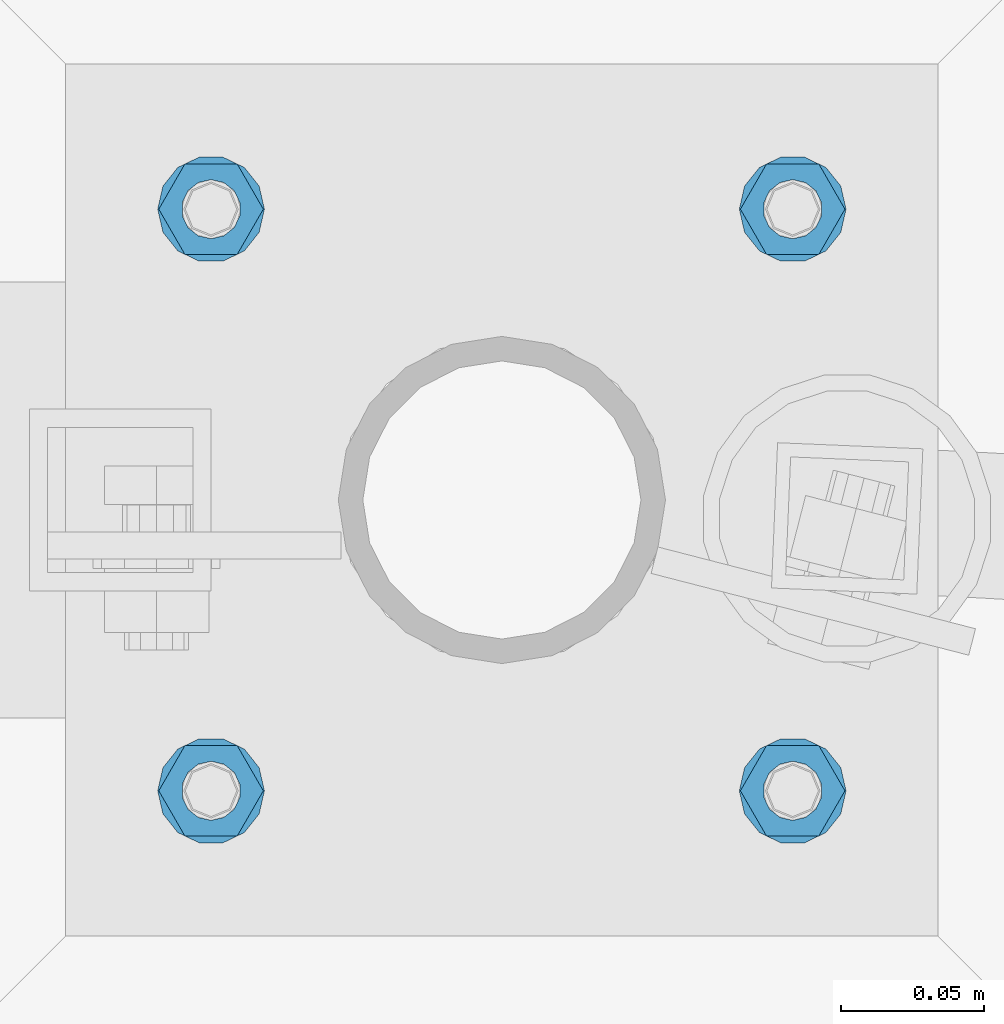
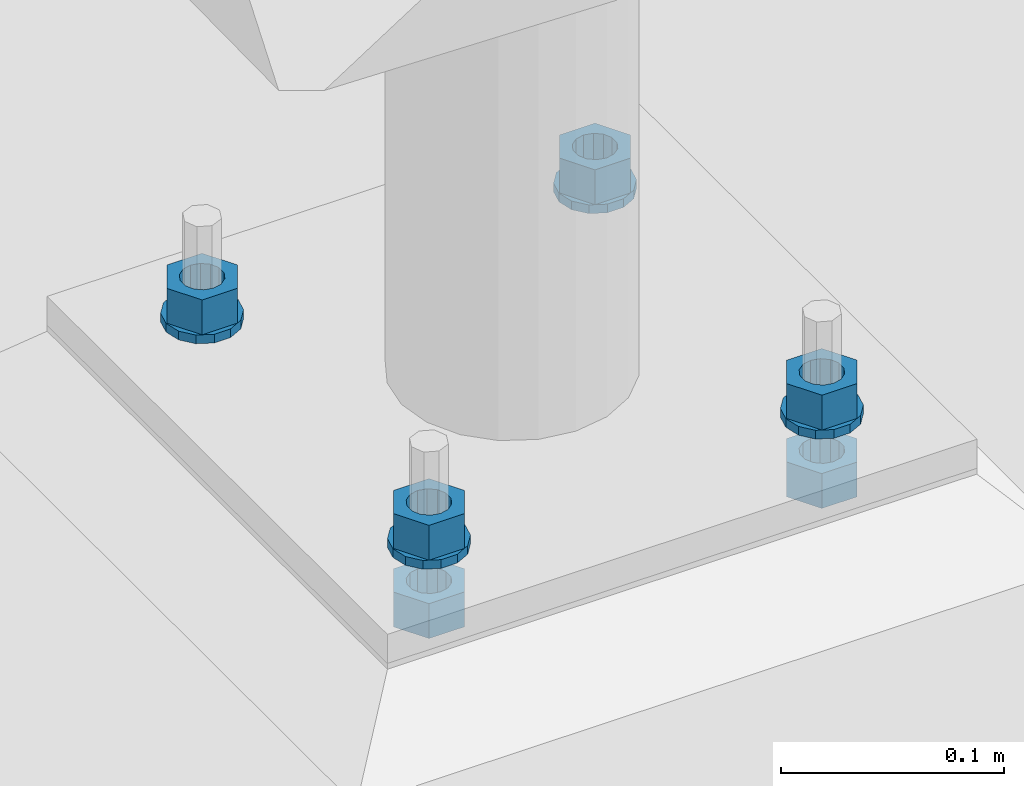
# One storey, part 631 of 975: 10 beams.
"""IFC2X3 building model written with IfcOpenShell, lengths in millimetres."""

from ifc_helpers import new_model, si_unit, frame, origin_with_axes, place, context, subcontext, project, spatial, faceted_brep, material, type_object, element, save


model = new_model("IFC2X3")

# Units and contexts
model_context = context("Model", 3, precision=1e-05, world=origin_with_axes())
body_context = subcontext(model_context, "Body", "Model", "MODEL_VIEW")
ifc_project = project(units=[si_unit("LENGTHUNIT", "METRE", prefix="MILLI"), si_unit("AREAUNIT", "SQUARE_METRE"), si_unit("VOLUMEUNIT", "CUBIC_METRE"), si_unit("MASSUNIT", "GRAM", prefix="KILO"), si_unit("TIMEUNIT", "SECOND"), si_unit("PLANEANGLEUNIT", "RADIAN"), si_unit("SOLIDANGLEUNIT", "STERADIAN"), si_unit("THERMODYNAMICTEMPERATUREUNIT", "DEGREE_CELSIUS"), si_unit("LUMINOUSINTENSITYUNIT", "LUMEN")], contexts=[model_context])

# Site, building, storey
site_placement = place(None, origin_with_axes())
site = spatial("IfcSite", under=ifc_project, at=site_placement, CompositionType="ELEMENT")
building_placement = place(site_placement, origin_with_axes())
building = spatial("IfcBuilding", under=site, at=building_placement, Name="Undefined", CompositionType="ELEMENT")
storey_placement = place(building_placement, origin_with_axes())
storey = spatial("IfcBuildingStorey", under=building, at=storey_placement, Name="Undefined", CompositionType="ELEMENT", Elevation=0.0)

# Beams
ifc_material = material(Name="STEEL/A36")
beam_type_1 = type_object("IfcBeamType", Name="3/4_WASHER", PredefinedType="NOTDEFINED")
beam_1_placement = place(storey_placement, frame((16322.6750015259, 29860.875, -242.887499999999), z_axis=(0.0, -1.0, 0.0), x_axis=(0.0, 0.0, -1.0)))
element("IfcBeam", 1, at=beam_1_placement, inside=storey, type_object=beam_type_1, material=ifc_material, Name="WASHER", ObjectType="3/4_WASHER", context=body_context, shape_type="Brep", body=[
    faceted_brep([(0.0, -18.6499996185303, 0.0), (0.0, -16.8030690426876, -8.09193156902904), (4.76250000000073, -16.8030690426876, -8.09193156902904), (4.76250000000073, -18.6499996185303, 0.0), (0.0, -11.6280845668225, -14.5811568497838), (4.76250000000073, -11.6280845668225, -14.5811568497838), (0.0, -4.15001533340001, -18.1824051902857), (4.76250000000073, -4.15001533340001, -18.1824051902857), (0.0, 4.15001533340001, -18.1824051902857), (4.76250000000073, 4.15001533340001, -18.1824051902857), (0.0, 11.6280845668234, -14.5811568497838), (4.76250000000073, 11.6280845668234, -14.5811568497838), (0.0, 16.8030690426876, -8.09193156902904), (4.76250000000073, 16.8030690426876, -8.09193156902904), (0.0, 18.6499996185303, 0.0), (4.76250000000073, 18.6499996185303, 0.0), (0.0, 16.8030690426876, 8.09193156902904), (4.76250000000073, 16.8030690426876, 8.09193156902904), (0.0, 11.6280845668225, 14.5811568497838), (4.76250000000073, 11.6280845668225, 14.5811568497838), (0.0, 4.15001533340001, 18.1824051902857), (4.76250000000073, 4.15001533340001, 18.1824051902857), (0.0, -4.15001533340001, 18.1824051902857), (4.76250000000073, -4.15001533340001, 18.1824051902857), (0.0, -11.6280845668234, 14.5811568497838), (4.76250000000073, -11.6280845668234, 14.5811568497838), (0.0, -16.8030690426876, 8.09193156902904), (4.76250000000073, -16.8030690426876, 8.09193156902904), (0.0, 0.0, 10.3199996948242), (0.0, 4.47768005528269, 9.29799844179911), (4.76250000000073, 4.47768005528269, 9.29799844179911), (4.76250000000073, 0.0, 10.3199996948242), (0.0, 8.06850066047446, 6.43441456490817), (4.76250000000073, 8.06850066047446, 6.43441456490817), (0.0, 10.0612557561917, 2.29641597052117), (4.76250000000073, 10.0612557561917, 2.29641597052117), (0.0, 10.0612557561917, -2.29641597052117), (4.76250000000073, 10.0612557561917, -2.29641597052117), (0.0, 8.06850066047446, -6.43441456490814), (4.76250000000073, 8.06850066047446, -6.43441456490814), (0.0, 4.47768005528269, -9.29799844179908), (4.76250000000073, 4.47768005528269, -9.29799844179908), (0.0, 0.0, -10.3199996948242), (4.76250000000073, 0.0, -10.3199996948242), (0.0, -4.47768005528269, -9.29799844179911), (4.76250000000073, -4.47768005528269, -9.29799844179911), (0.0, -8.06850066047446, -6.43441456490817), (4.76250000000073, -8.06850066047446, -6.43441456490817), (0.0, -10.0612557561917, -2.29641597052117), (4.76250000000073, -10.0612557561917, -2.29641597052117), (0.0, -10.0612557561917, 2.29641597052117), (4.76250000000073, -10.0612557561917, 2.29641597052117), (0.0, -8.06850066047446, 6.43441456490814), (4.76250000000073, -8.06850066047446, 6.43441456490814), (0.0, -4.47768005528269, 9.29799844179908), (4.76250000000073, -4.47768005528269, 9.29799844179908)], [[[0, 1, 2, 3]], [[1, 4, 5, 2]], [[4, 6, 7, 5]], [[6, 8, 9, 7]], [[8, 10, 11, 9]], [[10, 12, 13, 11]], [[12, 14, 15, 13]], [[14, 16, 17, 15]], [[16, 18, 19, 17]], [[18, 20, 21, 19]], [[20, 22, 23, 21]], [[22, 24, 25, 23]], [[24, 26, 27, 25]], [[26, 0, 3, 27]], [[28, 29, 30, 31]], [[29, 32, 33, 30]], [[32, 34, 35, 33]], [[34, 36, 37, 35]], [[36, 38, 39, 37]], [[38, 40, 41, 39]], [[40, 42, 43, 41]], [[42, 44, 45, 43]], [[44, 46, 47, 45]], [[46, 48, 49, 47]], [[48, 50, 51, 49]], [[50, 52, 53, 51]], [[52, 54, 55, 53]], [[54, 28, 31, 55]], [[5, 7, 9, 11, 13, 15, 17, 19, 21, 23, 25, 27, 3, 2], [33, 35, 37, 39, 41, 43, 45, 47, 49, 51, 53, 55, 31, 30]], [[26, 24, 22, 20, 18, 16, 14, 12, 10, 8, 6, 4, 1, 0], [54, 52, 50, 48, 46, 44, 42, 40, 38, 36, 34, 32, 29, 28]]]),
])
beam_2_placement = place(storey_placement, frame((16525.8749984741, 29860.875, -242.887499999999), z_axis=(0.0, 1.0, 0.0), x_axis=(0.0, 0.0, -1.0)))
element("IfcBeam", 2, at=beam_2_placement, inside=storey, type_object=beam_type_1, material=ifc_material, Name="WASHER", ObjectType="3/4_WASHER", context=body_context, shape_type="Brep", body=[
    faceted_brep([(0.0, -18.6499996185303, 0.0), (0.0, -16.8030690426876, -8.09193156902904), (4.76250000000073, -16.8030690426876, -8.09193156902904), (4.76250000000073, -18.6499996185303, 0.0), (0.0, -11.6280845668225, -14.5811568497838), (4.76250000000073, -11.6280845668225, -14.5811568497838), (0.0, -4.15001533340001, -18.1824051902857), (4.76250000000073, -4.15001533340001, -18.1824051902857), (0.0, 4.15001533340001, -18.1824051902857), (4.76250000000073, 4.15001533340001, -18.1824051902857), (0.0, 11.6280845668234, -14.5811568497838), (4.76250000000073, 11.6280845668234, -14.5811568497838), (0.0, 16.8030690426876, -8.09193156902904), (4.76250000000073, 16.8030690426876, -8.09193156902904), (0.0, 18.6499996185303, 0.0), (4.76250000000073, 18.6499996185303, 0.0), (0.0, 16.8030690426876, 8.09193156902904), (4.76250000000073, 16.8030690426876, 8.09193156902904), (0.0, 11.6280845668225, 14.5811568497838), (4.76250000000073, 11.6280845668225, 14.5811568497838), (0.0, 4.15001533340001, 18.1824051902857), (4.76250000000073, 4.15001533340001, 18.1824051902857), (0.0, -4.15001533340001, 18.1824051902857), (4.76250000000073, -4.15001533340001, 18.1824051902857), (0.0, -11.6280845668234, 14.5811568497838), (4.76250000000073, -11.6280845668234, 14.5811568497838), (0.0, -16.8030690426876, 8.09193156902904), (4.76250000000073, -16.8030690426876, 8.09193156902904), (0.0, 0.0, 10.3199996948242), (0.0, 4.47768005528269, 9.29799844179911), (4.76250000000073, 4.47768005528269, 9.29799844179911), (4.76250000000073, 0.0, 10.3199996948242), (0.0, 8.06850066047446, 6.43441456490817), (4.76250000000073, 8.06850066047446, 6.43441456490817), (0.0, 10.0612557561917, 2.29641597052117), (4.76250000000073, 10.0612557561917, 2.29641597052117), (0.0, 10.0612557561917, -2.29641597052117), (4.76250000000073, 10.0612557561917, -2.29641597052117), (0.0, 8.06850066047446, -6.43441456490814), (4.76250000000073, 8.06850066047446, -6.43441456490814), (0.0, 4.47768005528269, -9.29799844179908), (4.76250000000073, 4.47768005528269, -9.29799844179908), (0.0, 0.0, -10.3199996948242), (4.76250000000073, 0.0, -10.3199996948242), (0.0, -4.47768005528269, -9.29799844179911), (4.76250000000073, -4.47768005528269, -9.29799844179911), (0.0, -8.06850066047446, -6.43441456490817), (4.76250000000073, -8.06850066047446, -6.43441456490817), (0.0, -10.0612557561917, -2.29641597052117), (4.76250000000073, -10.0612557561917, -2.29641597052117), (0.0, -10.0612557561917, 2.29641597052117), (4.76250000000073, -10.0612557561917, 2.29641597052117), (0.0, -8.06850066047446, 6.43441456490814), (4.76250000000073, -8.06850066047446, 6.43441456490814), (0.0, -4.47768005528269, 9.29799844179908), (4.76250000000073, -4.47768005528269, 9.29799844179908)], [[[0, 1, 2, 3]], [[1, 4, 5, 2]], [[4, 6, 7, 5]], [[6, 8, 9, 7]], [[8, 10, 11, 9]], [[10, 12, 13, 11]], [[12, 14, 15, 13]], [[14, 16, 17, 15]], [[16, 18, 19, 17]], [[18, 20, 21, 19]], [[20, 22, 23, 21]], [[22, 24, 25, 23]], [[24, 26, 27, 25]], [[26, 0, 3, 27]], [[28, 29, 30, 31]], [[29, 32, 33, 30]], [[32, 34, 35, 33]], [[34, 36, 37, 35]], [[36, 38, 39, 37]], [[38, 40, 41, 39]], [[40, 42, 43, 41]], [[42, 44, 45, 43]], [[44, 46, 47, 45]], [[46, 48, 49, 47]], [[48, 50, 51, 49]], [[50, 52, 53, 51]], [[52, 54, 55, 53]], [[54, 28, 31, 55]], [[5, 7, 9, 11, 13, 15, 17, 19, 21, 23, 25, 27, 3, 2], [33, 35, 37, 39, 41, 43, 45, 47, 49, 51, 53, 55, 31, 30]], [[26, 24, 22, 20, 18, 16, 14, 12, 10, 8, 6, 4, 1, 0], [54, 52, 50, 48, 46, 44, 42, 40, 38, 36, 34, 32, 29, 28]]]),
])
beam_3_placement = place(storey_placement, frame((16322.6750015259, 30064.0749969482, -242.887499999999), z_axis=(0.0, -1.0, 0.0), x_axis=(0.0, 0.0, -1.0)))
element("IfcBeam", 3, at=beam_3_placement, inside=storey, type_object=beam_type_1, material=ifc_material, Name="WASHER", ObjectType="3/4_WASHER", context=body_context, shape_type="Brep", body=[
    faceted_brep([(0.0, -18.6499996185303, 0.0), (0.0, -16.8030690426876, -8.09193156902904), (4.76250000000073, -16.8030690426876, -8.09193156902904), (4.76250000000073, -18.6499996185303, 0.0), (0.0, -11.6280845668225, -14.5811568497838), (4.76250000000073, -11.6280845668225, -14.5811568497838), (0.0, -4.15001533340001, -18.1824051902857), (4.76250000000073, -4.15001533340001, -18.1824051902857), (0.0, 4.15001533340001, -18.1824051902857), (4.76250000000073, 4.15001533340001, -18.1824051902857), (0.0, 11.6280845668234, -14.5811568497838), (4.76250000000073, 11.6280845668234, -14.5811568497838), (0.0, 16.8030690426876, -8.09193156902904), (4.76250000000073, 16.8030690426876, -8.09193156902904), (0.0, 18.6499996185303, 0.0), (4.76250000000073, 18.6499996185303, 0.0), (0.0, 16.8030690426876, 8.09193156902904), (4.76250000000073, 16.8030690426876, 8.09193156902904), (0.0, 11.6280845668225, 14.5811568497838), (4.76250000000073, 11.6280845668225, 14.5811568497838), (0.0, 4.15001533340001, 18.1824051902857), (4.76250000000073, 4.15001533340001, 18.1824051902857), (0.0, -4.15001533340001, 18.1824051902857), (4.76250000000073, -4.15001533340001, 18.1824051902857), (0.0, -11.6280845668234, 14.5811568497838), (4.76250000000073, -11.6280845668234, 14.5811568497838), (0.0, -16.8030690426876, 8.09193156902904), (4.76250000000073, -16.8030690426876, 8.09193156902904), (0.0, 0.0, 10.3199996948242), (0.0, 4.47768005528269, 9.29799844179911), (4.76250000000073, 4.47768005528269, 9.29799844179911), (4.76250000000073, 0.0, 10.3199996948242), (0.0, 8.06850066047446, 6.43441456490817), (4.76250000000073, 8.06850066047446, 6.43441456490817), (0.0, 10.0612557561917, 2.29641597052117), (4.76250000000073, 10.0612557561917, 2.29641597052117), (0.0, 10.0612557561917, -2.29641597052117), (4.76250000000073, 10.0612557561917, -2.29641597052117), (0.0, 8.06850066047446, -6.43441456490814), (4.76250000000073, 8.06850066047446, -6.43441456490814), (0.0, 4.47768005528269, -9.29799844179908), (4.76250000000073, 4.47768005528269, -9.29799844179908), (0.0, 0.0, -10.3199996948242), (4.76250000000073, 0.0, -10.3199996948242), (0.0, -4.47768005528269, -9.29799844179911), (4.76250000000073, -4.47768005528269, -9.29799844179911), (0.0, -8.06850066047446, -6.43441456490817), (4.76250000000073, -8.06850066047446, -6.43441456490817), (0.0, -10.0612557561917, -2.29641597052117), (4.76250000000073, -10.0612557561917, -2.29641597052117), (0.0, -10.0612557561917, 2.29641597052117), (4.76250000000073, -10.0612557561917, 2.29641597052117), (0.0, -8.06850066047446, 6.43441456490814), (4.76250000000073, -8.06850066047446, 6.43441456490814), (0.0, -4.47768005528269, 9.29799844179908), (4.76250000000073, -4.47768005528269, 9.29799844179908)], [[[0, 1, 2, 3]], [[1, 4, 5, 2]], [[4, 6, 7, 5]], [[6, 8, 9, 7]], [[8, 10, 11, 9]], [[10, 12, 13, 11]], [[12, 14, 15, 13]], [[14, 16, 17, 15]], [[16, 18, 19, 17]], [[18, 20, 21, 19]], [[20, 22, 23, 21]], [[22, 24, 25, 23]], [[24, 26, 27, 25]], [[26, 0, 3, 27]], [[28, 29, 30, 31]], [[29, 32, 33, 30]], [[32, 34, 35, 33]], [[34, 36, 37, 35]], [[36, 38, 39, 37]], [[38, 40, 41, 39]], [[40, 42, 43, 41]], [[42, 44, 45, 43]], [[44, 46, 47, 45]], [[46, 48, 49, 47]], [[48, 50, 51, 49]], [[50, 52, 53, 51]], [[52, 54, 55, 53]], [[54, 28, 31, 55]], [[5, 7, 9, 11, 13, 15, 17, 19, 21, 23, 25, 27, 3, 2], [33, 35, 37, 39, 41, 43, 45, 47, 49, 51, 53, 55, 31, 30]], [[26, 24, 22, 20, 18, 16, 14, 12, 10, 8, 6, 4, 1, 0], [54, 52, 50, 48, 46, 44, 42, 40, 38, 36, 34, 32, 29, 28]]]),
])
beam_4_placement = place(storey_placement, frame((16525.8749984741, 30064.0749969482, -242.887499999999), z_axis=(0.0, 1.0, 0.0), x_axis=(0.0, 0.0, -1.0)))
element("IfcBeam", 4, at=beam_4_placement, inside=storey, type_object=beam_type_1, material=ifc_material, Name="WASHER", ObjectType="3/4_WASHER", context=body_context, shape_type="Brep", body=[
    faceted_brep([(0.0, -18.6499996185303, 0.0), (0.0, -16.8030690426876, -8.09193156902904), (4.76250000000073, -16.8030690426876, -8.09193156902904), (4.76250000000073, -18.6499996185303, 0.0), (0.0, -11.6280845668225, -14.5811568497838), (4.76250000000073, -11.6280845668225, -14.5811568497838), (0.0, -4.15001533340001, -18.1824051902857), (4.76250000000073, -4.15001533340001, -18.1824051902857), (0.0, 4.15001533340001, -18.1824051902857), (4.76250000000073, 4.15001533340001, -18.1824051902857), (0.0, 11.6280845668234, -14.5811568497838), (4.76250000000073, 11.6280845668234, -14.5811568497838), (0.0, 16.8030690426876, -8.09193156902904), (4.76250000000073, 16.8030690426876, -8.09193156902904), (0.0, 18.6499996185303, 0.0), (4.76250000000073, 18.6499996185303, 0.0), (0.0, 16.8030690426876, 8.09193156902904), (4.76250000000073, 16.8030690426876, 8.09193156902904), (0.0, 11.6280845668225, 14.5811568497838), (4.76250000000073, 11.6280845668225, 14.5811568497838), (0.0, 4.15001533340001, 18.1824051902857), (4.76250000000073, 4.15001533340001, 18.1824051902857), (0.0, -4.15001533340001, 18.1824051902857), (4.76250000000073, -4.15001533340001, 18.1824051902857), (0.0, -11.6280845668234, 14.5811568497838), (4.76250000000073, -11.6280845668234, 14.5811568497838), (0.0, -16.8030690426876, 8.09193156902904), (4.76250000000073, -16.8030690426876, 8.09193156902904), (0.0, 0.0, 10.3199996948242), (0.0, 4.47768005528269, 9.29799844179911), (4.76250000000073, 4.47768005528269, 9.29799844179911), (4.76250000000073, 0.0, 10.3199996948242), (0.0, 8.06850066047446, 6.43441456490817), (4.76250000000073, 8.06850066047446, 6.43441456490817), (0.0, 10.0612557561917, 2.29641597052117), (4.76250000000073, 10.0612557561917, 2.29641597052117), (0.0, 10.0612557561917, -2.29641597052117), (4.76250000000073, 10.0612557561917, -2.29641597052117), (0.0, 8.06850066047446, -6.43441456490814), (4.76250000000073, 8.06850066047446, -6.43441456490814), (0.0, 4.47768005528269, -9.29799844179908), (4.76250000000073, 4.47768005528269, -9.29799844179908), (0.0, 0.0, -10.3199996948242), (4.76250000000073, 0.0, -10.3199996948242), (0.0, -4.47768005528269, -9.29799844179911), (4.76250000000073, -4.47768005528269, -9.29799844179911), (0.0, -8.06850066047446, -6.43441456490817), (4.76250000000073, -8.06850066047446, -6.43441456490817), (0.0, -10.0612557561917, -2.29641597052117), (4.76250000000073, -10.0612557561917, -2.29641597052117), (0.0, -10.0612557561917, 2.29641597052117), (4.76250000000073, -10.0612557561917, 2.29641597052117), (0.0, -8.06850066047446, 6.43441456490814), (4.76250000000073, -8.06850066047446, 6.43441456490814), (0.0, -4.47768005528269, 9.29799844179908), (4.76250000000073, -4.47768005528269, 9.29799844179908)], [[[0, 1, 2, 3]], [[1, 4, 5, 2]], [[4, 6, 7, 5]], [[6, 8, 9, 7]], [[8, 10, 11, 9]], [[10, 12, 13, 11]], [[12, 14, 15, 13]], [[14, 16, 17, 15]], [[16, 18, 19, 17]], [[18, 20, 21, 19]], [[20, 22, 23, 21]], [[22, 24, 25, 23]], [[24, 26, 27, 25]], [[26, 0, 3, 27]], [[28, 29, 30, 31]], [[29, 32, 33, 30]], [[32, 34, 35, 33]], [[34, 36, 37, 35]], [[36, 38, 39, 37]], [[38, 40, 41, 39]], [[40, 42, 43, 41]], [[42, 44, 45, 43]], [[44, 46, 47, 45]], [[46, 48, 49, 47]], [[48, 50, 51, 49]], [[50, 52, 53, 51]], [[52, 54, 55, 53]], [[54, 28, 31, 55]], [[5, 7, 9, 11, 13, 15, 17, 19, 21, 23, 25, 27, 3, 2], [33, 35, 37, 39, 41, 43, 45, 47, 49, 51, 53, 55, 31, 30]], [[26, 24, 22, 20, 18, 16, 14, 12, 10, 8, 6, 4, 1, 0], [54, 52, 50, 48, 46, 44, 42, 40, 38, 36, 34, 32, 29, 28]]]),
])
beam_type_2 = type_object("IfcBeamType", Name="3/4_HEAVY_HEX_NUT", PredefinedType="NOTDEFINED")
beam_5_placement = place(storey_placement, frame((16322.6750015259, 29860.875, -223.8375), z_axis=(0.0, -1.0, 0.0), x_axis=(0.0, 0.0, -1.0)))
element("IfcBeam", 5, at=beam_5_placement, inside=storey, type_object=beam_type_2, material=ifc_material, Name="NUT", ObjectType="3/4_HEAVY_HEX_NUT", context=body_context, shape_type="Brep", body=[
    faceted_brep([(0.0, -18.2600002288818, 0.0), (0.0, -9.13000011444092, -15.8100004196167), (19.0499999999993, -9.13000011444092, -15.8100004196167), (19.0499999999993, -18.2600002288818, 0.0), (0.0, 9.13000011444092, -15.8100004196167), (19.0499999999993, 9.13000011444092, -15.8100004196167), (0.0, 18.2600002288818, 0.0), (19.0499999999993, 18.2600002288818, 0.0), (0.0, 9.13000011444092, 15.8100004196167), (19.0499999999993, 9.13000011444092, 15.8100004196167), (0.0, -9.13000011444092, 15.8100004196167), (19.0499999999993, -9.13000011444092, 15.8100004196167), (0.0, 0.0, 10.3199996948242), (0.0, 4.47768005528269, 9.29799844179911), (19.0499999999993, 4.47768005528269, 9.29799844179911), (19.0499999999993, 0.0, 10.3199996948242), (0.0, 8.06850066047446, 6.43441456490817), (19.0499999999993, 8.06850066047446, 6.43441456490817), (0.0, 10.0612557561917, 2.29641597052117), (19.0499999999993, 10.0612557561917, 2.29641597052117), (0.0, 10.0612557561917, -2.29641597052117), (19.0499999999993, 10.0612557561917, -2.29641597052117), (0.0, 8.06850066047446, -6.43441456490814), (19.0499999999993, 8.06850066047446, -6.43441456490814), (0.0, 4.47768005528269, -9.29799844179908), (19.0499999999993, 4.47768005528269, -9.29799844179908), (0.0, 0.0, -10.3199996948242), (19.0499999999993, 0.0, -10.3199996948242), (0.0, -4.47768005528269, -9.29799844179911), (19.0499999999993, -4.47768005528269, -9.29799844179911), (0.0, -8.06850066047446, -6.43441456490817), (19.0499999999993, -8.06850066047446, -6.43441456490817), (0.0, -10.0612557561917, -2.29641597052117), (19.0499999999993, -10.0612557561917, -2.29641597052117), (0.0, -10.0612557561917, 2.29641597052117), (19.0499999999993, -10.0612557561917, 2.29641597052117), (0.0, -8.06850066047446, 6.43441456490814), (19.0499999999993, -8.06850066047446, 6.43441456490814), (0.0, -4.47768005528269, 9.29799844179908), (19.0499999999993, -4.47768005528269, 9.29799844179908)], [[[0, 1, 2, 3]], [[1, 4, 5, 2]], [[4, 6, 7, 5]], [[6, 8, 9, 7]], [[8, 10, 11, 9]], [[10, 0, 3, 11]], [[12, 13, 14, 15]], [[13, 16, 17, 14]], [[16, 18, 19, 17]], [[18, 20, 21, 19]], [[20, 22, 23, 21]], [[22, 24, 25, 23]], [[24, 26, 27, 25]], [[26, 28, 29, 27]], [[28, 30, 31, 29]], [[30, 32, 33, 31]], [[32, 34, 35, 33]], [[34, 36, 37, 35]], [[36, 38, 39, 37]], [[38, 12, 15, 39]], [[5, 7, 9, 11, 3, 2], [17, 19, 21, 23, 25, 27, 29, 31, 33, 35, 37, 39, 15, 14]], [[10, 8, 6, 4, 1, 0], [38, 36, 34, 32, 30, 28, 26, 24, 22, 20, 18, 16, 13, 12]]]),
])
beam_6_placement = place(storey_placement, frame((16525.8749984741, 29860.875, -223.8375), z_axis=(0.0, 1.0, 0.0), x_axis=(0.0, 0.0, -1.0)))
element("IfcBeam", 6, at=beam_6_placement, inside=storey, type_object=beam_type_2, material=ifc_material, Name="NUT", ObjectType="3/4_HEAVY_HEX_NUT", context=body_context, shape_type="Brep", body=[
    faceted_brep([(0.0, -18.2600002288818, 0.0), (0.0, -9.13000011444092, -15.8100004196167), (19.0499999999993, -9.13000011444092, -15.8100004196167), (19.0499999999993, -18.2600002288818, 0.0), (0.0, 9.13000011444092, -15.8100004196167), (19.0499999999993, 9.13000011444092, -15.8100004196167), (0.0, 18.2600002288818, 0.0), (19.0499999999993, 18.2600002288818, 0.0), (0.0, 9.13000011444092, 15.8100004196167), (19.0499999999993, 9.13000011444092, 15.8100004196167), (0.0, -9.13000011444092, 15.8100004196167), (19.0499999999993, -9.13000011444092, 15.8100004196167), (0.0, 0.0, 10.3199996948242), (0.0, 4.47768005528269, 9.29799844179911), (19.0499999999993, 4.47768005528269, 9.29799844179911), (19.0499999999993, 0.0, 10.3199996948242), (0.0, 8.06850066047446, 6.43441456490817), (19.0499999999993, 8.06850066047446, 6.43441456490817), (0.0, 10.0612557561917, 2.29641597052117), (19.0499999999993, 10.0612557561917, 2.29641597052117), (0.0, 10.0612557561917, -2.29641597052117), (19.0499999999993, 10.0612557561917, -2.29641597052117), (0.0, 8.06850066047446, -6.43441456490814), (19.0499999999993, 8.06850066047446, -6.43441456490814), (0.0, 4.47768005528269, -9.29799844179908), (19.0499999999993, 4.47768005528269, -9.29799844179908), (0.0, 0.0, -10.3199996948242), (19.0499999999993, 0.0, -10.3199996948242), (0.0, -4.47768005528269, -9.29799844179911), (19.0499999999993, -4.47768005528269, -9.29799844179911), (0.0, -8.06850066047446, -6.43441456490817), (19.0499999999993, -8.06850066047446, -6.43441456490817), (0.0, -10.0612557561917, -2.29641597052117), (19.0499999999993, -10.0612557561917, -2.29641597052117), (0.0, -10.0612557561917, 2.29641597052117), (19.0499999999993, -10.0612557561917, 2.29641597052117), (0.0, -8.06850066047446, 6.43441456490814), (19.0499999999993, -8.06850066047446, 6.43441456490814), (0.0, -4.47768005528269, 9.29799844179908), (19.0499999999993, -4.47768005528269, 9.29799844179908)], [[[0, 1, 2, 3]], [[1, 4, 5, 2]], [[4, 6, 7, 5]], [[6, 8, 9, 7]], [[8, 10, 11, 9]], [[10, 0, 3, 11]], [[12, 13, 14, 15]], [[13, 16, 17, 14]], [[16, 18, 19, 17]], [[18, 20, 21, 19]], [[20, 22, 23, 21]], [[22, 24, 25, 23]], [[24, 26, 27, 25]], [[26, 28, 29, 27]], [[28, 30, 31, 29]], [[30, 32, 33, 31]], [[32, 34, 35, 33]], [[34, 36, 37, 35]], [[36, 38, 39, 37]], [[38, 12, 15, 39]], [[5, 7, 9, 11, 3, 2], [17, 19, 21, 23, 25, 27, 29, 31, 33, 35, 37, 39, 15, 14]], [[10, 8, 6, 4, 1, 0], [38, 36, 34, 32, 30, 28, 26, 24, 22, 20, 18, 16, 13, 12]]]),
])
beam_7_placement = place(storey_placement, frame((16322.6750015259, 30064.0749969482, -223.8375), z_axis=(0.0, -1.0, 0.0), x_axis=(0.0, 0.0, -1.0)))
element("IfcBeam", 7, at=beam_7_placement, inside=storey, type_object=beam_type_2, material=ifc_material, Name="NUT", ObjectType="3/4_HEAVY_HEX_NUT", context=body_context, shape_type="Brep", body=[
    faceted_brep([(0.0, -18.2600002288818, 0.0), (0.0, -9.13000011444092, -15.8100004196167), (19.0499999999993, -9.13000011444092, -15.8100004196167), (19.0499999999993, -18.2600002288818, 0.0), (0.0, 9.13000011444092, -15.8100004196167), (19.0499999999993, 9.13000011444092, -15.8100004196167), (0.0, 18.2600002288818, 0.0), (19.0499999999993, 18.2600002288818, 0.0), (0.0, 9.13000011444092, 15.8100004196167), (19.0499999999993, 9.13000011444092, 15.8100004196167), (0.0, -9.13000011444092, 15.8100004196167), (19.0499999999993, -9.13000011444092, 15.8100004196167), (0.0, 0.0, 10.3199996948242), (0.0, 4.47768005528269, 9.29799844179911), (19.0499999999993, 4.47768005528269, 9.29799844179911), (19.0499999999993, 0.0, 10.3199996948242), (0.0, 8.06850066047446, 6.43441456490817), (19.0499999999993, 8.06850066047446, 6.43441456490817), (0.0, 10.0612557561917, 2.29641597052117), (19.0499999999993, 10.0612557561917, 2.29641597052117), (0.0, 10.0612557561917, -2.29641597052117), (19.0499999999993, 10.0612557561917, -2.29641597052117), (0.0, 8.06850066047446, -6.43441456490814), (19.0499999999993, 8.06850066047446, -6.43441456490814), (0.0, 4.47768005528269, -9.29799844179908), (19.0499999999993, 4.47768005528269, -9.29799844179908), (0.0, 0.0, -10.3199996948242), (19.0499999999993, 0.0, -10.3199996948242), (0.0, -4.47768005528269, -9.29799844179911), (19.0499999999993, -4.47768005528269, -9.29799844179911), (0.0, -8.06850066047446, -6.43441456490817), (19.0499999999993, -8.06850066047446, -6.43441456490817), (0.0, -10.0612557561917, -2.29641597052117), (19.0499999999993, -10.0612557561917, -2.29641597052117), (0.0, -10.0612557561917, 2.29641597052117), (19.0499999999993, -10.0612557561917, 2.29641597052117), (0.0, -8.06850066047446, 6.43441456490814), (19.0499999999993, -8.06850066047446, 6.43441456490814), (0.0, -4.47768005528269, 9.29799844179908), (19.0499999999993, -4.47768005528269, 9.29799844179908)], [[[0, 1, 2, 3]], [[1, 4, 5, 2]], [[4, 6, 7, 5]], [[6, 8, 9, 7]], [[8, 10, 11, 9]], [[10, 0, 3, 11]], [[12, 13, 14, 15]], [[13, 16, 17, 14]], [[16, 18, 19, 17]], [[18, 20, 21, 19]], [[20, 22, 23, 21]], [[22, 24, 25, 23]], [[24, 26, 27, 25]], [[26, 28, 29, 27]], [[28, 30, 31, 29]], [[30, 32, 33, 31]], [[32, 34, 35, 33]], [[34, 36, 37, 35]], [[36, 38, 39, 37]], [[38, 12, 15, 39]], [[5, 7, 9, 11, 3, 2], [17, 19, 21, 23, 25, 27, 29, 31, 33, 35, 37, 39, 15, 14]], [[10, 8, 6, 4, 1, 0], [38, 36, 34, 32, 30, 28, 26, 24, 22, 20, 18, 16, 13, 12]]]),
])
beam_8_placement = place(storey_placement, frame((16525.8749984741, 30064.0749969482, -223.8375), z_axis=(0.0, 1.0, 0.0), x_axis=(0.0, 0.0, -1.0)))
element("IfcBeam", 8, at=beam_8_placement, inside=storey, type_object=beam_type_2, material=ifc_material, Name="NUT", ObjectType="3/4_HEAVY_HEX_NUT", context=body_context, shape_type="Brep", body=[
    faceted_brep([(0.0, -18.2600002288818, 0.0), (0.0, -9.13000011444092, -15.8100004196167), (19.0499999999993, -9.13000011444092, -15.8100004196167), (19.0499999999993, -18.2600002288818, 0.0), (0.0, 9.13000011444092, -15.8100004196167), (19.0499999999993, 9.13000011444092, -15.8100004196167), (0.0, 18.2600002288818, 0.0), (19.0499999999993, 18.2600002288818, 0.0), (0.0, 9.13000011444092, 15.8100004196167), (19.0499999999993, 9.13000011444092, 15.8100004196167), (0.0, -9.13000011444092, 15.8100004196167), (19.0499999999993, -9.13000011444092, 15.8100004196167), (0.0, 0.0, 10.3199996948242), (0.0, 4.47768005528269, 9.29799844179911), (19.0499999999993, 4.47768005528269, 9.29799844179911), (19.0499999999993, 0.0, 10.3199996948242), (0.0, 8.06850066047446, 6.43441456490817), (19.0499999999993, 8.06850066047446, 6.43441456490817), (0.0, 10.0612557561917, 2.29641597052117), (19.0499999999993, 10.0612557561917, 2.29641597052117), (0.0, 10.0612557561917, -2.29641597052117), (19.0499999999993, 10.0612557561917, -2.29641597052117), (0.0, 8.06850066047446, -6.43441456490814), (19.0499999999993, 8.06850066047446, -6.43441456490814), (0.0, 4.47768005528269, -9.29799844179908), (19.0499999999993, 4.47768005528269, -9.29799844179908), (0.0, 0.0, -10.3199996948242), (19.0499999999993, 0.0, -10.3199996948242), (0.0, -4.47768005528269, -9.29799844179911), (19.0499999999993, -4.47768005528269, -9.29799844179911), (0.0, -8.06850066047446, -6.43441456490817), (19.0499999999993, -8.06850066047446, -6.43441456490817), (0.0, -10.0612557561917, -2.29641597052117), (19.0499999999993, -10.0612557561917, -2.29641597052117), (0.0, -10.0612557561917, 2.29641597052117), (19.0499999999993, -10.0612557561917, 2.29641597052117), (0.0, -8.06850066047446, 6.43441456490814), (19.0499999999993, -8.06850066047446, 6.43441456490814), (0.0, -4.47768005528269, 9.29799844179908), (19.0499999999993, -4.47768005528269, 9.29799844179908)], [[[0, 1, 2, 3]], [[1, 4, 5, 2]], [[4, 6, 7, 5]], [[6, 8, 9, 7]], [[8, 10, 11, 9]], [[10, 0, 3, 11]], [[12, 13, 14, 15]], [[13, 16, 17, 14]], [[16, 18, 19, 17]], [[18, 20, 21, 19]], [[20, 22, 23, 21]], [[22, 24, 25, 23]], [[24, 26, 27, 25]], [[26, 28, 29, 27]], [[28, 30, 31, 29]], [[30, 32, 33, 31]], [[32, 34, 35, 33]], [[34, 36, 37, 35]], [[36, 38, 39, 37]], [[38, 12, 15, 39]], [[5, 7, 9, 11, 3, 2], [17, 19, 21, 23, 25, 27, 29, 31, 33, 35, 37, 39, 15, 14]], [[10, 8, 6, 4, 1, 0], [38, 36, 34, 32, 30, 28, 26, 24, 22, 20, 18, 16, 13, 12]]]),
])
beam_9_placement = place(storey_placement, frame((16322.6750015259, 29860.875, -266.699999999999), z_axis=(0.0, -1.0, 0.0), x_axis=(0.0, 0.0, -1.0)))
element("IfcBeam", 9, at=beam_9_placement, inside=storey, type_object=beam_type_2, material=ifc_material, Name="NUT", ObjectType="3/4_HEAVY_HEX_NUT", context=body_context, shape_type="Brep", body=[
    faceted_brep([(0.0, -18.2600002288818, 0.0), (0.0, -9.13000011444092, -15.8100004196167), (19.0499999999993, -9.13000011444092, -15.8100004196167), (19.0499999999993, -18.2600002288818, 0.0), (0.0, 9.13000011444092, -15.8100004196167), (19.0499999999993, 9.13000011444092, -15.8100004196167), (0.0, 18.2600002288818, 0.0), (19.0499999999993, 18.2600002288818, 0.0), (0.0, 9.13000011444092, 15.8100004196167), (19.0499999999993, 9.13000011444092, 15.8100004196167), (0.0, -9.13000011444092, 15.8100004196167), (19.0499999999993, -9.13000011444092, 15.8100004196167), (0.0, 0.0, 10.3199996948242), (0.0, 4.47768005528269, 9.29799844179911), (19.0499999999993, 4.47768005528269, 9.29799844179911), (19.0499999999993, 0.0, 10.3199996948242), (0.0, 8.06850066047446, 6.43441456490817), (19.0499999999993, 8.06850066047446, 6.43441456490817), (0.0, 10.0612557561917, 2.29641597052117), (19.0499999999993, 10.0612557561917, 2.29641597052117), (0.0, 10.0612557561917, -2.29641597052117), (19.0499999999993, 10.0612557561917, -2.29641597052117), (0.0, 8.06850066047446, -6.43441456490814), (19.0499999999993, 8.06850066047446, -6.43441456490814), (0.0, 4.47768005528269, -9.29799844179908), (19.0499999999993, 4.47768005528269, -9.29799844179908), (0.0, 0.0, -10.3199996948242), (19.0499999999993, 0.0, -10.3199996948242), (0.0, -4.47768005528269, -9.29799844179911), (19.0499999999993, -4.47768005528269, -9.29799844179911), (0.0, -8.06850066047446, -6.43441456490817), (19.0499999999993, -8.06850066047446, -6.43441456490817), (0.0, -10.0612557561917, -2.29641597052117), (19.0499999999993, -10.0612557561917, -2.29641597052117), (0.0, -10.0612557561917, 2.29641597052117), (19.0499999999993, -10.0612557561917, 2.29641597052117), (0.0, -8.06850066047446, 6.43441456490814), (19.0499999999993, -8.06850066047446, 6.43441456490814), (0.0, -4.47768005528269, 9.29799844179908), (19.0499999999993, -4.47768005528269, 9.29799844179908)], [[[0, 1, 2, 3]], [[1, 4, 5, 2]], [[4, 6, 7, 5]], [[6, 8, 9, 7]], [[8, 10, 11, 9]], [[10, 0, 3, 11]], [[12, 13, 14, 15]], [[13, 16, 17, 14]], [[16, 18, 19, 17]], [[18, 20, 21, 19]], [[20, 22, 23, 21]], [[22, 24, 25, 23]], [[24, 26, 27, 25]], [[26, 28, 29, 27]], [[28, 30, 31, 29]], [[30, 32, 33, 31]], [[32, 34, 35, 33]], [[34, 36, 37, 35]], [[36, 38, 39, 37]], [[38, 12, 15, 39]], [[5, 7, 9, 11, 3, 2], [17, 19, 21, 23, 25, 27, 29, 31, 33, 35, 37, 39, 15, 14]], [[10, 8, 6, 4, 1, 0], [38, 36, 34, 32, 30, 28, 26, 24, 22, 20, 18, 16, 13, 12]]]),
])
beam_10_placement = place(storey_placement, frame((16525.8749984741, 29860.875, -266.699999999999), z_axis=(0.0, 1.0, 0.0), x_axis=(0.0, 0.0, -1.0)))
element("IfcBeam", 10, at=beam_10_placement, inside=storey, type_object=beam_type_2, material=ifc_material, Name="NUT", ObjectType="3/4_HEAVY_HEX_NUT", context=body_context, shape_type="Brep", body=[
    faceted_brep([(0.0, -18.2600002288818, 0.0), (0.0, -9.13000011444092, -15.8100004196167), (19.0499999999993, -9.13000011444092, -15.8100004196167), (19.0499999999993, -18.2600002288818, 0.0), (0.0, 9.13000011444092, -15.8100004196167), (19.0499999999993, 9.13000011444092, -15.8100004196167), (0.0, 18.2600002288818, 0.0), (19.0499999999993, 18.2600002288818, 0.0), (0.0, 9.13000011444092, 15.8100004196167), (19.0499999999993, 9.13000011444092, 15.8100004196167), (0.0, -9.13000011444092, 15.8100004196167), (19.0499999999993, -9.13000011444092, 15.8100004196167), (0.0, 0.0, 10.3199996948242), (0.0, 4.47768005528269, 9.29799844179911), (19.0499999999993, 4.47768005528269, 9.29799844179911), (19.0499999999993, 0.0, 10.3199996948242), (0.0, 8.06850066047446, 6.43441456490817), (19.0499999999993, 8.06850066047446, 6.43441456490817), (0.0, 10.0612557561917, 2.29641597052117), (19.0499999999993, 10.0612557561917, 2.29641597052117), (0.0, 10.0612557561917, -2.29641597052117), (19.0499999999993, 10.0612557561917, -2.29641597052117), (0.0, 8.06850066047446, -6.43441456490814), (19.0499999999993, 8.06850066047446, -6.43441456490814), (0.0, 4.47768005528269, -9.29799844179908), (19.0499999999993, 4.47768005528269, -9.29799844179908), (0.0, 0.0, -10.3199996948242), (19.0499999999993, 0.0, -10.3199996948242), (0.0, -4.47768005528269, -9.29799844179911), (19.0499999999993, -4.47768005528269, -9.29799844179911), (0.0, -8.06850066047446, -6.43441456490817), (19.0499999999993, -8.06850066047446, -6.43441456490817), (0.0, -10.0612557561917, -2.29641597052117), (19.0499999999993, -10.0612557561917, -2.29641597052117), (0.0, -10.0612557561917, 2.29641597052117), (19.0499999999993, -10.0612557561917, 2.29641597052117), (0.0, -8.06850066047446, 6.43441456490814), (19.0499999999993, -8.06850066047446, 6.43441456490814), (0.0, -4.47768005528269, 9.29799844179908), (19.0499999999993, -4.47768005528269, 9.29799844179908)], [[[0, 1, 2, 3]], [[1, 4, 5, 2]], [[4, 6, 7, 5]], [[6, 8, 9, 7]], [[8, 10, 11, 9]], [[10, 0, 3, 11]], [[12, 13, 14, 15]], [[13, 16, 17, 14]], [[16, 18, 19, 17]], [[18, 20, 21, 19]], [[20, 22, 23, 21]], [[22, 24, 25, 23]], [[24, 26, 27, 25]], [[26, 28, 29, 27]], [[28, 30, 31, 29]], [[30, 32, 33, 31]], [[32, 34, 35, 33]], [[34, 36, 37, 35]], [[36, 38, 39, 37]], [[38, 12, 15, 39]], [[5, 7, 9, 11, 3, 2], [17, 19, 21, 23, 25, 27, 29, 31, 33, 35, 37, 39, 15, 14]], [[10, 8, 6, 4, 1, 0], [38, 36, 34, 32, 30, 28, 26, 24, 22, 20, 18, 16, 13, 12]]]),
])

save(model, "model.ifc")
